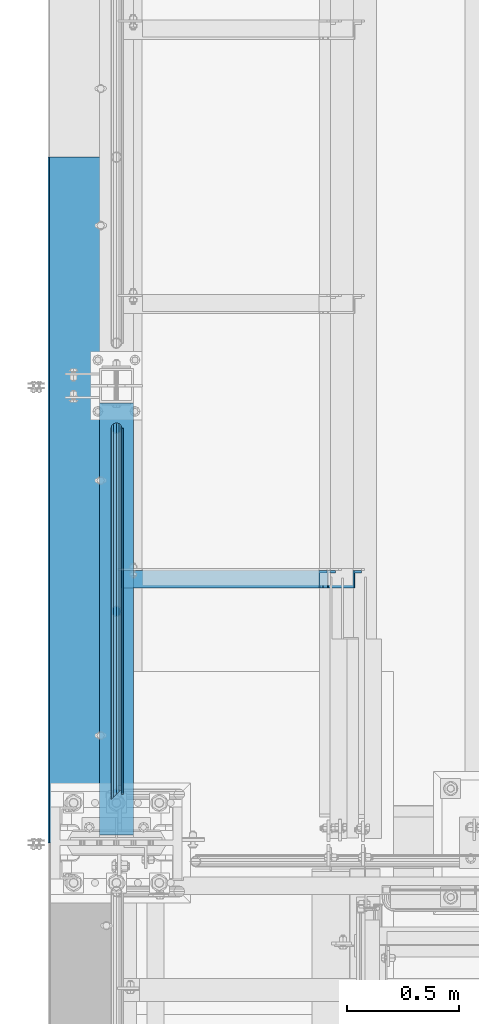
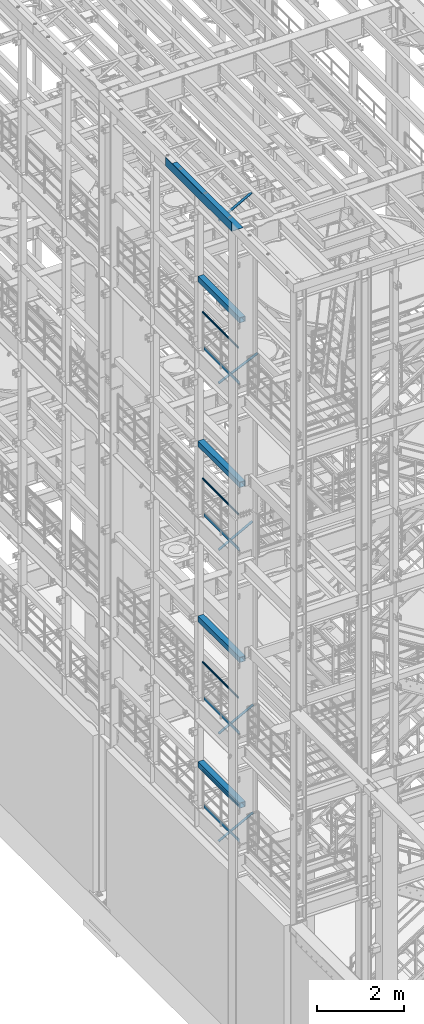
# One storey, part 970 of 1876: 13 beams, 5 members, 14 elements without a shape of their own.
"""IFC2X3 building model written with IfcOpenShell, lengths in millimetres."""

import ifcopenshell
import ifcopenshell.guid

model = None  # the IFC model being written
_history = None  # IfcOwnerHistory: only IFC2X3 demands one
_inside = {}  # id of a spatial element -> (the spatial element, [elements in it])
_under = {}  # id of a project, library or spatial element -> (it, [spatial elements below it])
_declared = {}  # id of a project -> (the project, [libraries it declares])
_typed = {}  # id of a type object -> (the type object, [elements of that type])
_made_of = {}  # id of a material, layer set ... -> (it, [elements and type objects made of it])


def new_model(schema):
    """Start an empty IFC model of exactly this schema.

    Asked for "IFC4X3", IfcOpenShell would pick the latest addendum, in which some entities
    have other attributes; the version numbers below select the first issue.
    IFC2X3 requires an IfcOwnerHistory on every rooted entity: one is made here for all.
    """
    global model, _history
    if schema == "IFC4X3":
        model = ifcopenshell.file(schema_version=(4, 3, 0, 0))
    else:
        model = ifcopenshell.file(schema=schema)
    _inside.clear()
    _under.clear()
    _declared.clear()
    _typed.clear()
    _made_of.clear()
    _history = None
    if model.schema == "IFC2X3":
        org = make("IfcOrganization", Name="unknown")
        user = make(
            "IfcPersonAndOrganization",
            ThePerson=make("IfcPerson", FamilyName="unknown"),
            TheOrganization=org,
        )
        app = make(
            "IfcApplication",
            ApplicationDeveloper=org,
            Version="unknown",
            ApplicationFullName="unknown",
            ApplicationIdentifier="unknown",
        )
        _history = make(
            "IfcOwnerHistory",
            OwningUser=user,
            OwningApplication=app,
            ChangeAction="ADDED",
            CreationDate=0,
        )
    return model


def make(cls, **values):
    """One entity of the class cls with the attributes given. An attribute that is None is left unset."""
    return model.create_entity(
        cls, **{name: value for name, value in values.items() if value is not None}
    )


def rooted(cls, **values):
    """An entity with a GlobalId (a new one), such as an element, a storey or a relation."""
    return make(cls, GlobalId=ifcopenshell.guid.new(), OwnerHistory=_history, **values)


def si_unit(unit_type, name, prefix=None):
    """IfcSIUnit, for example si_unit("LENGTHUNIT", "METRE", prefix="MILLI")."""
    return make("IfcSIUnit", UnitType=unit_type, Prefix=prefix, Name=name)


def assignment(units):
    """IfcUnitAssignment: the units of a project."""
    return None if units is None else make("IfcUnitAssignment", Units=units)


def point(xyz):
    """IfcCartesianPoint."""
    return None if xyz is None else make("IfcCartesianPoint", Coordinates=xyz)


def direction(xyz):
    """IfcDirection."""
    return None if xyz is None else make("IfcDirection", DirectionRatios=xyz)


def frame(location, z_axis=None, x_axis=None):
    """IfcAxis2Placement3D, a coordinate frame: its origin and axes. An axis left out is left unset."""
    return make(
        "IfcAxis2Placement3D",
        Location=point(location),
        Axis=direction(z_axis),
        RefDirection=direction(x_axis),
    )


def origin_with_axes():
    """The frame at (0, 0, 0) with the z axis (0, 0, 1) and the x axis (1, 0, 0) written out."""
    return frame((0.0, 0.0, 0.0), z_axis=(0.0, 0.0, 1.0), x_axis=(1.0, 0.0, 0.0))


def place(relative_to, where):
    """IfcLocalPlacement: puts the frame where relative to a parent placement (None: the world)."""
    return make(
        "IfcLocalPlacement", PlacementRelTo=relative_to, RelativePlacement=where
    )


def context(
    kind, dimensions, precision=None, world=None, true_north=None, identifier=None
):
    """IfcGeometricRepresentationContext, for example the 3D "Model" context."""
    return make(
        "IfcGeometricRepresentationContext",
        ContextIdentifier=identifier,
        ContextType=kind,
        CoordinateSpaceDimension=dimensions,
        Precision=precision,
        WorldCoordinateSystem=world,
        TrueNorth=true_north,
    )


def subcontext(parent, identifier, kind, view, scale=None):
    """IfcGeometricRepresentationSubContext, for example "Body" below "Model"."""
    return make(
        "IfcGeometricRepresentationSubContext",
        ContextIdentifier=identifier,
        ContextType=kind,
        ParentContext=parent,
        TargetScale=scale,
        TargetView=view,
    )


def project(units=None, contexts=None):
    """IfcProject with its units and contexts."""
    return rooted(
        "IfcProject",
        Name="project",
        RepresentationContexts=contexts,
        UnitsInContext=assignment(units),
    )


def spatial(cls, under=None, at=None, **own):
    """A site, building, storey or space (cls), placed at a placement, below another one or the project."""
    s = rooted(cls, ObjectPlacement=at, **own)
    if under is not None:
        _under.setdefault(under.id(), (under, []))[1].append(s)
    return s


def faces_of(points, faces, orient=None, outer=None):
    """IfcFace entities. A face is a list of loops; a loop is a list of indices into points, from 0.

    orient and outer hold one flag for each loop. By default every Orientation is true, the
    first loop of a face is its IfcFaceOuterBound and the others are IfcFaceBound.
    """
    made = []
    for i, loops in enumerate(faces):
        bounds = []
        for j, loop in enumerate(loops):
            is_outer = j == 0 if outer is None else outer[i][j]
            bounds.append(
                make(
                    "IfcFaceOuterBound" if is_outer else "IfcFaceBound",
                    Bound=make("IfcPolyLoop", Polygon=[points[k] for k in loop]),
                    Orientation=True if orient is None else orient[i][j],
                )
            )
        made.append(make("IfcFace", Bounds=bounds))
    return made


def faceted_brep(points, faces, orient=None, outer=None, voids=None):
    """IfcFacetedBrep: a solid bounded by flat faces; with voids (closed shells), ...WithVoids."""
    shared = [point(p) for p in points]
    hull = make("IfcClosedShell", CfsFaces=faces_of(shared, faces, orient, outer))
    if voids is None:
        return make("IfcFacetedBrep", Outer=hull)
    return make(
        "IfcFacetedBrepWithVoids",
        Outer=hull,
        Voids=[
            make(cls, CfsFaces=faces_of(shared, fs, o, b)) for cls, fs, o, b in voids
        ],
    )


def shape(context_of_items, identifier, shape_type, items):
    """IfcShapeRepresentation: the items that make up one representation, for example the "Body"."""
    return make(
        "IfcShapeRepresentation",
        ContextOfItems=context_of_items,
        RepresentationIdentifier=identifier,
        RepresentationType=shape_type,
        Items=items,
    )


def material(Name=None, Category=None):
    """IfcMaterial."""
    return make("IfcMaterial", Name=Name, Category=Category)


def made_of(thing, what):
    """Note that an element or type object is made of a material, layer set ...; save() writes the relation."""
    if what is not None:
        _made_of.setdefault(what.id(), (what, []))[1].append(thing)
    return thing


def type_object(cls, material=None, **own):
    """A type object (cls), such as IfcWallType, which elements share."""
    return made_of(rooted(cls, **own), material)


def element(
    cls,
    number,
    at=None,
    inside=None,
    cuts=None,
    type_object=None,
    material=None,
    context=None,
    identifier="Body",
    shape_type=None,
    held_by="IfcProductDefinitionShape",
    body=None,
    shapes=None,
    **own,
):
    """One element of the class cls, such as IfcWall. Its Tag is "e" and its number.

    at: its placement. inside: the storey or other place that contains it. cuts: it is an
    opening in that element (IfcRelVoidsElement). A single representation is given by context,
    identifier, shape_type and body (its items); several are given by shapes. held_by: the class
    of the entity that holds the representations. save() writes the other relations.
    """
    e = rooted(cls, Tag="e%d" % number, ObjectPlacement=at, **own)
    if body is not None:
        shapes = [shape(context, identifier, shape_type, body)]
    if shapes is not None:
        e.Representation = make(held_by, Representations=shapes)
    if inside is not None:
        _inside.setdefault(inside.id(), (inside, []))[1].append(e)
    if cuts is not None:
        rooted(
            "IfcRelVoidsElement", RelatingBuildingElement=cuts, RelatedOpeningElement=e
        )
    if type_object is not None:
        _typed.setdefault(type_object.id(), (type_object, []))[1].append(e)
    return made_of(e, material)


def aggregate(whole, parts):
    """IfcRelAggregates: a whole, such as a stair, and the parts it consists of."""
    return rooted("IfcRelAggregates", RelatingObject=whole, RelatedObjects=parts)


def save(model, path):
    """Write the relations noted so far, then the file.

    IfcRelAggregates (storeys below a building ...), IfcRelContainedInSpatialStructure (elements
    in a storey), IfcRelDefinesByType, IfcRelAssociatesMaterial and IfcRelDeclares: one each for
    every whole, place, type object, material and project.
    """
    for whole, parts in _under.values():
        aggregate(whole, parts)
    for where, things in _inside.values():
        rooted(
            "IfcRelContainedInSpatialStructure",
            RelatedElements=things,
            RelatingStructure=where,
        )
    for kind, things in _typed.values():
        rooted("IfcRelDefinesByType", RelatedObjects=things, RelatingType=kind)
    for what, things in _made_of.values():
        rooted("IfcRelAssociatesMaterial", RelatedObjects=things, RelatingMaterial=what)
    for by, libraries in _declared.values():
        rooted("IfcRelDeclares", RelatingContext=by, RelatedDefinitions=libraries)
    model.write(path)


model = new_model("IFC2X3")

# Units and contexts
model_context = context("Model", 3, precision=1e-05, world=origin_with_axes())
body_context = subcontext(model_context, "Body", "Model", "MODEL_VIEW")
ifc_project = project(units=[si_unit("LENGTHUNIT", "METRE", prefix="MILLI"), si_unit("AREAUNIT", "SQUARE_METRE"), si_unit("VOLUMEUNIT", "CUBIC_METRE"), si_unit("MASSUNIT", "GRAM", prefix="KILO"), si_unit("TIMEUNIT", "SECOND"), si_unit("PLANEANGLEUNIT", "RADIAN"), si_unit("SOLIDANGLEUNIT", "STERADIAN"), si_unit("THERMODYNAMICTEMPERATUREUNIT", "DEGREE_CELSIUS"), si_unit("LUMINOUSINTENSITYUNIT", "LUMEN")], contexts=[model_context])

# Site, building, storey
site_placement = place(None, origin_with_axes())
site = spatial("IfcSite", under=ifc_project, at=site_placement, CompositionType="ELEMENT")
building_placement = place(site_placement, origin_with_axes())
building = spatial("IfcBuilding", under=site, at=building_placement, Name="Undefined", CompositionType="ELEMENT")
storey_placement = place(building_placement, origin_with_axes())
storey = spatial("IfcBuildingStorey", under=building, at=storey_placement, Name="Undefined", CompositionType="ELEMENT", Elevation=0.0)

# Assembly, beam
assembly_1_placement = place(storey_placement, origin_with_axes())
assembly_1 = element("IfcElementAssembly", 1, at=assembly_1_placement, inside=storey, Name="RAIL", AssemblyPlace="NOTDEFINED", PredefinedType="RIGID_FRAME")
ifc_material_1 = material()
beam_type_1 = type_object("IfcBeamType", Name="PIPE1-1/2SCH40", PredefinedType="NOTDEFINED")
beam_1_placement = place(assembly_1_placement, frame((-4.42285052611689e-13, -4380.23, 19059.525), z_axis=(0.0, 0.0, -1.0), x_axis=(0.0, 1.0, 0.0)))
beam_1 = element("IfcBeam", 2, at=beam_1_placement, type_object=beam_type_1, material=ifc_material_1, Name="RAIL", ObjectType="PIPE1-1/2SCH40", context=body_context, shape_type="Brep", body=[
    faceted_brep([(3.68299999999272, -20.447, 0.0), (6.42237856881275, -17.7076214311804, 10.2235000000001), (1640.7003, -17.7076214311801, 10.2235000000001), (1650.9238, -20.4470000000001, 0.0), (13.9064999999928, -10.2235, 17.7076214311819), (1633.21617856882, -10.2235000000001, 17.7076214311819), (24.1300000000064, 0.0, 20.4470000000001), (1630.4768, 0.0, 20.4470000000001), (34.3534999999929, 10.2235, 17.7076214311819), (1633.21617856882, 10.2235000000001, 17.7076214311819), (41.8376214311729, 17.7076214311804, 10.2235000000001), (1640.7003, 17.7076214311801, 10.2235000000001), (44.5769999999929, 20.447, 0.0), (1650.9238, 20.4470000000001, 0.0), (41.8376214311729, 17.7076214311804, -10.2235000000001), (1661.1473, 17.7076214311801, -10.2235000000001), (34.3534999999929, 10.2235, -17.7076214311819), (1668.63142143118, 10.2235000000001, -17.7076214311819), (24.1300000000063, 0.0, -20.4470000000001), (1671.3708, 0.0, -20.4470000000001), (13.9064999999928, -10.2235, -17.7076214311819), (1668.63142143118, -10.2235000000001, -17.7076214311819), (6.42237856881275, -17.7076214311804, -10.2235000000001), (1661.1473, -17.7076214311801, -10.2235000000001), (0.0, -24.1299999999992, 0.0), (3.23280700667419, -20.8971929933185, -12.0649999999987), (1662.9888, -20.8971929933186, -12.0649999999987), (1650.9238, -24.1300000000001, 0.0), (12.0649999999854, -12.0650000000005, -20.8971929933177), (1671.82099299332, -12.0649999999996, -20.8971929933177), (24.1300000000063, 0.0, -24.130000000001), (1675.0538, 0.0, -24.130000000001), (36.1949999999924, 12.065, -20.8971929933177), (1671.82099299332, 12.0649999999996, -20.8971929933177), (45.0271929933115, 20.8971929933185, -12.0649999999987), (1662.9888, 20.8971929933186, -12.0649999999987), (48.2599999999929, 24.13, 0.0), (1650.9238, 24.1300000000001, 0.0), (45.0271929933115, 20.8971929933185, 12.0649999999987), (1638.8588, 20.8971929933186, 12.0649999999987), (36.1949999999924, 12.065, 20.8971929933177), (1630.02660700668, 12.0649999999996, 20.8971929933177), (24.1300000000064, 0.0, 24.130000000001), (1626.7938, 0.0, 24.130000000001), (12.0649999999854, -12.0650000000005, 20.8971929933177), (1630.02660700668, -12.0649999999996, 20.8971929933177), (3.23280700667419, -20.8971929933185, 12.0649999999987), (1638.8588, -20.8971929933186, 12.0649999999987)], [[[0, 1, 2, 3]], [[1, 4, 5, 2]], [[4, 6, 7, 5]], [[6, 8, 9, 7]], [[8, 10, 11, 9]], [[10, 12, 13, 11]], [[12, 14, 15, 13]], [[14, 16, 17, 15]], [[16, 18, 19, 17]], [[18, 20, 21, 19]], [[20, 22, 23, 21]], [[22, 0, 3, 23]], [[24, 25, 26, 27]], [[25, 28, 29, 26]], [[28, 30, 31, 29]], [[30, 32, 33, 31]], [[32, 34, 35, 33]], [[34, 36, 37, 35]], [[36, 38, 39, 37]], [[38, 40, 41, 39]], [[40, 42, 43, 41]], [[42, 44, 45, 43]], [[44, 46, 47, 45]], [[46, 24, 27, 47]], [[29, 31, 33, 35, 37, 39, 41, 43, 45, 47, 27, 26], [5, 7, 9, 11, 13, 15, 17, 19, 21, 23, 3, 2]], [[46, 44, 42, 40, 38, 36, 34, 32, 30, 28, 25, 24], [22, 20, 18, 16, 14, 12, 10, 8, 6, 4, 1, 0]]]),
])

assembly_2_placement = place(storey_placement, origin_with_axes())
assembly_2 = element("IfcElementAssembly", 3, at=assembly_2_placement, inside=storey, Name="RAIL", AssemblyPlace="NOTDEFINED", PredefinedType="RIGID_FRAME")
beam_2_placement = place(assembly_2_placement, frame((-4.42285052611689e-13, -4380.23, 14385.925), z_axis=(0.0, 0.0, -1.0), x_axis=(0.0, 1.0, 0.0)))
beam_2 = element("IfcBeam", 4, at=beam_2_placement, type_object=beam_type_1, material=ifc_material_1, Name="RAIL", ObjectType="PIPE1-1/2SCH40", context=body_context, shape_type="Brep", body=[
    faceted_brep([(3.68299999999272, -20.447, 0.0), (6.42237856881275, -17.7076214311804, 10.2235000000001), (1640.7003, -17.7076214311801, 10.2235000000001), (1650.9238, -20.4470000000001, 0.0), (13.9064999999928, -10.2235, 17.7076214311819), (1633.21617856882, -10.2235000000001, 17.7076214311819), (24.1300000000064, 0.0, 20.4470000000001), (1630.4768, 0.0, 20.4470000000001), (34.3534999999929, 10.2235, 17.7076214311819), (1633.21617856882, 10.2235000000001, 17.7076214311819), (41.8376214311729, 17.7076214311804, 10.2235000000001), (1640.7003, 17.7076214311801, 10.2235000000001), (44.5769999999929, 20.447, 0.0), (1650.9238, 20.4470000000001, 0.0), (41.8376214311729, 17.7076214311804, -10.2235000000001), (1661.1473, 17.7076214311801, -10.2235000000001), (34.3534999999929, 10.2235, -17.7076214311819), (1668.63142143118, 10.2235000000001, -17.7076214311819), (24.1300000000063, 0.0, -20.4470000000001), (1671.3708, 0.0, -20.4470000000001), (13.9064999999928, -10.2235, -17.7076214311819), (1668.63142143118, -10.2235000000001, -17.7076214311819), (6.42237856881275, -17.7076214311804, -10.2235000000001), (1661.1473, -17.7076214311801, -10.2235000000001), (0.0, -24.1299999999992, 0.0), (3.23280700667419, -20.8971929933185, -12.0649999999987), (1662.9888, -20.8971929933186, -12.0649999999987), (1650.9238, -24.1300000000001, 0.0), (12.0649999999854, -12.0650000000005, -20.8971929933177), (1671.82099299332, -12.0649999999996, -20.8971929933177), (24.1300000000063, 0.0, -24.130000000001), (1675.0538, 0.0, -24.130000000001), (36.1949999999924, 12.065, -20.8971929933177), (1671.82099299332, 12.0649999999996, -20.8971929933177), (45.0271929933115, 20.8971929933185, -12.0649999999987), (1662.9888, 20.8971929933186, -12.0649999999987), (48.2599999999929, 24.13, 0.0), (1650.9238, 24.1300000000001, 0.0), (45.0271929933115, 20.8971929933185, 12.0649999999987), (1638.8588, 20.8971929933186, 12.0649999999987), (36.1949999999924, 12.065, 20.8971929933177), (1630.02660700668, 12.0649999999996, 20.8971929933177), (24.1300000000064, 0.0, 24.130000000001), (1626.7938, 0.0, 24.130000000001), (12.0649999999854, -12.0650000000005, 20.8971929933177), (1630.02660700668, -12.0649999999996, 20.8971929933177), (3.23280700667419, -20.8971929933185, 12.0649999999987), (1638.8588, -20.8971929933186, 12.0649999999987)], [[[0, 1, 2, 3]], [[1, 4, 5, 2]], [[4, 6, 7, 5]], [[6, 8, 9, 7]], [[8, 10, 11, 9]], [[10, 12, 13, 11]], [[12, 14, 15, 13]], [[14, 16, 17, 15]], [[16, 18, 19, 17]], [[18, 20, 21, 19]], [[20, 22, 23, 21]], [[22, 0, 3, 23]], [[24, 25, 26, 27]], [[25, 28, 29, 26]], [[28, 30, 31, 29]], [[30, 32, 33, 31]], [[32, 34, 35, 33]], [[34, 36, 37, 35]], [[36, 38, 39, 37]], [[38, 40, 41, 39]], [[40, 42, 43, 41]], [[42, 44, 45, 43]], [[44, 46, 47, 45]], [[46, 24, 27, 47]], [[29, 31, 33, 35, 37, 39, 41, 43, 45, 47, 27, 26], [5, 7, 9, 11, 13, 15, 17, 19, 21, 23, 3, 2]], [[46, 44, 42, 40, 38, 36, 34, 32, 30, 28, 25, 24], [22, 20, 18, 16, 14, 12, 10, 8, 6, 4, 1, 0]]]),
])

assembly_3_placement = place(storey_placement, origin_with_axes())
assembly_3 = element("IfcElementAssembly", 5, at=assembly_3_placement, inside=storey, Name="RAIL", AssemblyPlace="NOTDEFINED", PredefinedType="RIGID_FRAME")
beam_3_placement = place(assembly_3_placement, frame((-4.42285052611689e-13, -4380.23, 9229.725), z_axis=(0.0, 0.0, -1.0), x_axis=(0.0, 1.0, 0.0)))
beam_3 = element("IfcBeam", 6, at=beam_3_placement, type_object=beam_type_1, material=ifc_material_1, Name="RAIL", ObjectType="PIPE1-1/2SCH40", context=body_context, shape_type="Brep", body=[
    faceted_brep([(3.68299999999272, -20.447, 0.0), (6.42237856881275, -17.7076214311804, 10.2235000000001), (1640.7003, -17.7076214311801, 10.2235000000001), (1650.9238, -20.4470000000001, 0.0), (13.9064999999928, -10.2235, 17.7076214311819), (1633.21617856882, -10.2235000000001, 17.7076214311819), (24.1300000000064, 0.0, 20.4470000000001), (1630.4768, 0.0, 20.4470000000001), (34.3534999999929, 10.2235, 17.7076214311819), (1633.21617856882, 10.2235000000001, 17.7076214311819), (41.8376214311729, 17.7076214311804, 10.2235000000001), (1640.7003, 17.7076214311801, 10.2235000000001), (44.5769999999929, 20.447, 0.0), (1650.9238, 20.4470000000001, 0.0), (41.8376214311729, 17.7076214311804, -10.2235000000001), (1661.1473, 17.7076214311801, -10.2235000000001), (34.3534999999929, 10.2235, -17.7076214311819), (1668.63142143118, 10.2235000000001, -17.7076214311819), (24.1300000000063, 0.0, -20.4470000000001), (1671.3708, 0.0, -20.4470000000001), (13.9064999999928, -10.2235, -17.7076214311819), (1668.63142143118, -10.2235000000001, -17.7076214311819), (6.42237856881275, -17.7076214311804, -10.2235000000001), (1661.1473, -17.7076214311801, -10.2235000000001), (0.0, -24.1299999999992, 0.0), (3.23280700667419, -20.8971929933185, -12.0649999999987), (1662.9888, -20.8971929933186, -12.0649999999987), (1650.9238, -24.1300000000001, 0.0), (12.0649999999854, -12.0650000000005, -20.8971929933177), (1671.82099299332, -12.0649999999996, -20.8971929933177), (24.1300000000063, 0.0, -24.130000000001), (1675.0538, 0.0, -24.130000000001), (36.1949999999924, 12.065, -20.8971929933177), (1671.82099299332, 12.0649999999996, -20.8971929933177), (45.0271929933115, 20.8971929933185, -12.0649999999987), (1662.9888, 20.8971929933186, -12.0649999999987), (48.2599999999929, 24.13, 0.0), (1650.9238, 24.1300000000001, 0.0), (45.0271929933115, 20.8971929933185, 12.0649999999987), (1638.8588, 20.8971929933186, 12.0649999999987), (36.1949999999924, 12.065, 20.8971929933177), (1630.02660700668, 12.0649999999996, 20.8971929933177), (24.1300000000064, 0.0, 24.130000000001), (1626.7938, 0.0, 24.130000000001), (12.0649999999854, -12.0650000000005, 20.8971929933177), (1630.02660700668, -12.0649999999996, 20.8971929933177), (3.23280700667419, -20.8971929933185, 12.0649999999987), (1638.8588, -20.8971929933186, 12.0649999999987)], [[[0, 1, 2, 3]], [[1, 4, 5, 2]], [[4, 6, 7, 5]], [[6, 8, 9, 7]], [[8, 10, 11, 9]], [[10, 12, 13, 11]], [[12, 14, 15, 13]], [[14, 16, 17, 15]], [[16, 18, 19, 17]], [[18, 20, 21, 19]], [[20, 22, 23, 21]], [[22, 0, 3, 23]], [[24, 25, 26, 27]], [[25, 28, 29, 26]], [[28, 30, 31, 29]], [[30, 32, 33, 31]], [[32, 34, 35, 33]], [[34, 36, 37, 35]], [[36, 38, 39, 37]], [[38, 40, 41, 39]], [[40, 42, 43, 41]], [[42, 44, 45, 43]], [[44, 46, 47, 45]], [[46, 24, 27, 47]], [[29, 31, 33, 35, 37, 39, 41, 43, 45, 47, 27, 26], [5, 7, 9, 11, 13, 15, 17, 19, 21, 23, 3, 2]], [[46, 44, 42, 40, 38, 36, 34, 32, 30, 28, 25, 24], [22, 20, 18, 16, 14, 12, 10, 8, 6, 4, 1, 0]]]),
])

assembly_4_placement = place(storey_placement, origin_with_axes())
assembly_4 = element("IfcElementAssembly", 7, at=assembly_4_placement, inside=storey, Name="RAIL", AssemblyPlace="NOTDEFINED", PredefinedType="RIGID_FRAME")
beam_4_placement = place(assembly_4_placement, frame((-4.42285052611689e-13, -4380.23, 6207.125), z_axis=(0.0, 0.0, -1.0), x_axis=(0.0, 1.0, 0.0)))
beam_4 = element("IfcBeam", 8, at=beam_4_placement, type_object=beam_type_1, material=ifc_material_1, Name="RAIL", ObjectType="PIPE1-1/2SCH40", context=body_context, shape_type="Brep", body=[
    faceted_brep([(3.68299999999272, -20.447, 0.0), (6.42237856881275, -17.7076214311804, 10.2235000000001), (1640.7003, -17.7076214311801, 10.2235000000001), (1650.9238, -20.4470000000001, 0.0), (13.9064999999928, -10.2235, 17.7076214311819), (1633.21617856882, -10.2235000000001, 17.7076214311819), (24.1300000000064, 0.0, 20.4470000000001), (1630.4768, 0.0, 20.4470000000001), (34.3534999999929, 10.2235, 17.7076214311819), (1633.21617856882, 10.2235000000001, 17.7076214311819), (41.8376214311729, 17.7076214311804, 10.2235000000001), (1640.7003, 17.7076214311801, 10.2235000000001), (44.5769999999929, 20.447, 0.0), (1650.9238, 20.4470000000001, 0.0), (41.8376214311729, 17.7076214311804, -10.2235000000001), (1661.1473, 17.7076214311801, -10.2235000000001), (34.3534999999929, 10.2235, -17.7076214311819), (1668.63142143118, 10.2235000000001, -17.7076214311819), (24.1300000000063, 0.0, -20.4470000000001), (1671.3708, 0.0, -20.4470000000001), (13.9064999999928, -10.2235, -17.7076214311819), (1668.63142143118, -10.2235000000001, -17.7076214311819), (6.42237856881275, -17.7076214311804, -10.2235000000001), (1661.1473, -17.7076214311801, -10.2235000000001), (0.0, -24.1299999999992, 0.0), (3.23280700667419, -20.8971929933185, -12.0649999999987), (1662.9888, -20.8971929933186, -12.0649999999987), (1650.9238, -24.1300000000001, 0.0), (12.0649999999854, -12.0650000000005, -20.8971929933177), (1671.82099299332, -12.0649999999996, -20.8971929933177), (24.1300000000063, 0.0, -24.130000000001), (1675.0538, 0.0, -24.130000000001), (36.1949999999924, 12.065, -20.8971929933177), (1671.82099299332, 12.0649999999996, -20.8971929933177), (45.0271929933115, 20.8971929933185, -12.0649999999987), (1662.9888, 20.8971929933186, -12.0649999999987), (48.2599999999929, 24.13, 0.0), (1650.9238, 24.1300000000001, 0.0), (45.0271929933115, 20.8971929933185, 12.0649999999987), (1638.8588, 20.8971929933186, 12.0649999999987), (36.1949999999924, 12.065, 20.8971929933177), (1630.02660700668, 12.0649999999996, 20.8971929933177), (24.1300000000064, 0.0, 24.130000000001), (1626.7938, 0.0, 24.130000000001), (12.0649999999854, -12.0650000000005, 20.8971929933177), (1630.02660700668, -12.0649999999996, 20.8971929933177), (3.23280700667419, -20.8971929933185, 12.0649999999987), (1638.8588, -20.8971929933186, 12.0649999999987)], [[[0, 1, 2, 3]], [[1, 4, 5, 2]], [[4, 6, 7, 5]], [[6, 8, 9, 7]], [[8, 10, 11, 9]], [[10, 12, 13, 11]], [[12, 14, 15, 13]], [[14, 16, 17, 15]], [[16, 18, 19, 17]], [[18, 20, 21, 19]], [[20, 22, 23, 21]], [[22, 0, 3, 23]], [[24, 25, 26, 27]], [[25, 28, 29, 26]], [[28, 30, 31, 29]], [[30, 32, 33, 31]], [[32, 34, 35, 33]], [[34, 36, 37, 35]], [[36, 38, 39, 37]], [[38, 40, 41, 39]], [[40, 42, 43, 41]], [[42, 44, 45, 43]], [[44, 46, 47, 45]], [[46, 24, 27, 47]], [[29, 31, 33, 35, 37, 39, 41, 43, 45, 47, 27, 26], [5, 7, 9, 11, 13, 15, 17, 19, 21, 23, 3, 2]], [[46, 44, 42, 40, 38, 36, 34, 32, 30, 28, 25, 24], [22, 20, 18, 16, 14, 12, 10, 8, 6, 4, 1, 0]]]),
])

assembly_5_placement = place(storey_placement, origin_with_axes())
assembly_5 = element("IfcElementAssembly", 9, at=assembly_5_placement, inside=storey, Name="BEAM", AssemblyPlace="NOTDEFINED", PredefinedType="RIGID_FRAME")
ifc_material_2 = material()
beam_type_2 = type_object("IfcBeamType", Name="HSS6X6X3/8", PredefinedType="NOTDEFINED")
beam_5_placement = place(assembly_5_placement, frame((0.0, -4560.09375, 19958.05), z_axis=(-1.0, 0.0, 0.0), x_axis=(0.0, 1.0, 0.0)))
beam_5 = element("IfcBeam", 10, at=beam_5_placement, type_object=beam_type_2, material=ifc_material_2, Name="BEAM", ObjectType="HSS6X6X3/8", context=body_context, shape_type="Brep", body=[
    faceted_brep([(22.2249999999995, 66.6749999999993, -66.675), (22.2249999999995, -66.6749999999993, -66.675), (1943.89375, -66.6749999999993, -66.675), (1943.89375, 66.6749999999993, -66.675), (22.2249999999995, -66.6749999999993, 66.675), (1943.89375, -66.6749999999993, 66.675), (22.2249999999995, 66.6749999999993, 66.675), (1943.89375, 66.6749999999993, 66.675), (22.2249999999995, 76.2000000000007, -76.2), (22.2249999999995, 76.2000000000007, 76.2), (1943.89375, 76.2000000000007, 76.2), (1943.89375, 76.2000000000007, -76.2), (22.2249999999995, -76.2000000000007, 76.2), (1943.89375, -76.2000000000007, 76.2), (22.2249999999995, -76.2000000000007, -76.2), (1943.89375, -76.2000000000007, -76.2)], [[[0, 1, 2, 3]], [[1, 4, 5, 2]], [[4, 6, 7, 5]], [[6, 0, 3, 7]], [[8, 9, 10, 11]], [[9, 12, 13, 10]], [[12, 14, 15, 13]], [[14, 8, 11, 15]], [[13, 15, 11, 10], [5, 7, 3, 2]], [[14, 12, 9, 8], [6, 4, 1, 0]]]),
])
aggregate(assembly_5, [beam_5])

assembly_6_placement = place(storey_placement, origin_with_axes())
assembly_6 = element("IfcElementAssembly", 11, at=assembly_6_placement, inside=storey, Name="BEAM", AssemblyPlace="NOTDEFINED", PredefinedType="RIGID_FRAME")
beam_6_placement = place(assembly_6_placement, frame((0.0, -4560.09375, 15335.25), z_axis=(-1.0, 0.0, 0.0), x_axis=(0.0, 1.0, 0.0)))
beam_6 = element("IfcBeam", 12, at=beam_6_placement, type_object=beam_type_2, material=ifc_material_2, Name="BEAM", ObjectType="HSS6X6X3/8", context=body_context, shape_type="Brep", body=[
    faceted_brep([(22.2249999999995, 66.6749999999993, -66.675), (22.2249999999995, -66.6749999999993, -66.675), (1943.89375, -66.6749999999993, -66.675), (1943.89375, 66.6749999999993, -66.675), (22.2249999999995, -66.6749999999993, 66.675), (1943.89375, -66.6749999999993, 66.675), (22.2249999999995, 66.6749999999993, 66.675), (1943.89375, 66.6749999999993, 66.675), (22.2249999999995, 76.2000000000007, -76.2), (22.2249999999995, 76.2000000000007, 76.2), (1943.89375, 76.2000000000007, 76.2), (1943.89375, 76.2000000000007, -76.2), (22.2249999999995, -76.2000000000007, 76.2), (1943.89375, -76.2000000000007, 76.2), (22.2249999999995, -76.2000000000007, -76.2), (1943.89375, -76.2000000000007, -76.2)], [[[0, 1, 2, 3]], [[1, 4, 5, 2]], [[4, 6, 7, 5]], [[6, 0, 3, 7]], [[8, 9, 10, 11]], [[9, 12, 13, 10]], [[12, 14, 15, 13]], [[14, 8, 11, 15]], [[13, 15, 11, 10], [5, 7, 3, 2]], [[14, 12, 9, 8], [6, 4, 1, 0]]]),
])
aggregate(assembly_6, [beam_6])

assembly_7_placement = place(storey_placement, origin_with_axes())
assembly_7 = element("IfcElementAssembly", 13, at=assembly_7_placement, inside=storey, Name="BEAM", AssemblyPlace="NOTDEFINED", PredefinedType="RIGID_FRAME")
beam_7_placement = place(assembly_7_placement, frame((0.0, -4560.09375, 10420.35), z_axis=(-1.0, 0.0, 0.0), x_axis=(0.0, 1.0, 0.0)))
beam_7 = element("IfcBeam", 14, at=beam_7_placement, type_object=beam_type_2, material=ifc_material_2, Name="BEAM", ObjectType="HSS6X6X3/8", context=body_context, shape_type="Brep", body=[
    faceted_brep([(22.2249999999995, 66.6749999999993, -66.675), (22.2249999999995, -66.6749999999993, -66.675), (1943.89375, -66.6749999999993, -66.675), (1943.89375, 66.6749999999993, -66.675), (22.2249999999995, -66.6749999999993, 66.675), (1943.89375, -66.6749999999993, 66.675), (22.2249999999995, 66.6749999999993, 66.675), (1943.89375, 66.6749999999993, 66.675), (22.2249999999995, 76.2000000000007, -76.2), (22.2249999999995, 76.2000000000007, 76.2), (1943.89375, 76.2000000000007, 76.2), (1943.89375, 76.2000000000007, -76.2), (22.2249999999995, -76.2000000000007, 76.2), (1943.89375, -76.2000000000007, 76.2), (22.2249999999995, -76.2000000000007, -76.2), (1943.89375, -76.2000000000007, -76.2)], [[[0, 1, 2, 3]], [[1, 4, 5, 2]], [[4, 6, 7, 5]], [[6, 0, 3, 7]], [[8, 9, 10, 11]], [[9, 12, 13, 10]], [[12, 14, 15, 13]], [[14, 8, 11, 15]], [[13, 15, 11, 10], [5, 7, 3, 2]], [[14, 12, 9, 8], [6, 4, 1, 0]]]),
])
aggregate(assembly_7, [beam_7])

assembly_8_placement = place(storey_placement, origin_with_axes())
assembly_8 = element("IfcElementAssembly", 15, at=assembly_8_placement, inside=storey, Name="BEAM", AssemblyPlace="NOTDEFINED", PredefinedType="RIGID_FRAME")
beam_8_placement = place(assembly_8_placement, frame((0.0, -4560.09375, 6330.95), z_axis=(-1.0, 0.0, 0.0), x_axis=(0.0, 1.0, 0.0)))
beam_8 = element("IfcBeam", 16, at=beam_8_placement, type_object=beam_type_2, material=ifc_material_2, Name="BEAM", ObjectType="HSS6X6X3/8", context=body_context, shape_type="Brep", body=[
    faceted_brep([(22.2249999999995, 66.6749999999993, -66.675), (22.2249999999995, -66.6749999999993, -66.675), (1943.89375, -66.6749999999993, -66.675), (1943.89375, 66.6749999999993, -66.675), (22.2249999999995, -66.6749999999993, 66.675), (1943.89375, -66.6749999999993, 66.675), (22.2249999999995, 66.6749999999993, 66.675), (1943.89375, 66.6749999999993, 66.675), (22.2249999999995, 76.2000000000007, -76.2), (22.2249999999995, 76.2000000000007, 76.2), (1943.89375, 76.2000000000007, 76.2), (1943.89375, 76.2000000000007, -76.2), (22.2249999999995, -76.2000000000007, 76.2), (1943.89375, -76.2000000000007, 76.2), (22.2249999999995, -76.2000000000007, -76.2), (1943.89375, -76.2000000000007, -76.2)], [[[0, 1, 2, 3]], [[1, 4, 5, 2]], [[4, 6, 7, 5]], [[6, 0, 3, 7]], [[8, 9, 10, 11]], [[9, 12, 13, 10]], [[12, 14, 15, 13]], [[14, 8, 11, 15]], [[13, 15, 11, 10], [5, 7, 3, 2]], [[14, 12, 9, 8], [6, 4, 1, 0]]]),
])
aggregate(assembly_8, [beam_8])

# Beam
ifc_material_3 = material(Name="STEEL/A36")
beam_type_3 = type_object("IfcBeamType", PredefinedType="NOTDEFINED")
beam_9_placement = place(assembly_1_placement, frame((27.3049999999948, -4356.10000000001, 18049.875), z_axis=(0.0, 0.0, 1.0), x_axis=(0.0, 1.0, 0.0)))
beam_9 = element("IfcBeam", 17, at=beam_9_placement, type_object=beam_type_3, material=ifc_material_3, Name="PLATE", context=body_context, shape_type="Brep", body=[
    faceted_brep([(0.0, 3.17500000000018, -50.8000000000002), (0.0, 3.17500000000018, 50.8000000000002), (1626.7938, 3.175, 50.7999999999993), (1626.7938, 3.175, -50.7999999999993), (0.0, -3.17500000000018, 50.8000000000002), (1626.7938, -3.175, 50.7999999999993), (0.0, -3.17500000000018, -50.8000000000002), (1626.7938, -3.175, -50.7999999999993)], [[[0, 1, 2, 3]], [[1, 4, 5, 2]], [[4, 6, 7, 5]], [[6, 0, 3, 7]], [[5, 7, 3, 2]], [[6, 4, 1, 0]]]),
])

aggregate(assembly_1, [beam_9, beam_1])

beam_10_placement = place(assembly_2_placement, frame((27.3049999999948, -4356.10000000001, 13376.275), z_axis=(0.0, 0.0, 1.0), x_axis=(0.0, 1.0, 0.0)))
beam_10 = element("IfcBeam", 18, at=beam_10_placement, type_object=beam_type_3, material=ifc_material_3, Name="PLATE", context=body_context, shape_type="Brep", body=[
    faceted_brep([(0.0, 3.17500000000018, -50.8000000000002), (0.0, 3.17500000000018, 50.8000000000002), (1626.7938, 3.175, 50.7999999999993), (1626.7938, 3.175, -50.7999999999993), (0.0, -3.17500000000018, 50.8000000000002), (1626.7938, -3.175, 50.7999999999993), (0.0, -3.17500000000018, -50.8000000000002), (1626.7938, -3.175, -50.7999999999993)], [[[0, 1, 2, 3]], [[1, 4, 5, 2]], [[4, 6, 7, 5]], [[6, 0, 3, 7]], [[5, 7, 3, 2]], [[6, 4, 1, 0]]]),
])

aggregate(assembly_2, [beam_10, beam_2])

beam_11_placement = place(assembly_3_placement, frame((27.3049999999948, -4356.1, 8220.075), z_axis=(0.0, 0.0, 1.0), x_axis=(0.0, 1.0, 0.0)))
beam_11 = element("IfcBeam", 19, at=beam_11_placement, type_object=beam_type_3, material=ifc_material_3, Name="PLATE", context=body_context, shape_type="Brep", body=[
    faceted_brep([(0.0, 3.17500000000018, -50.8000000000002), (0.0, 3.17500000000018, 50.8000000000002), (1626.7938, 3.175, 50.7999999999993), (1626.7938, 3.175, -50.7999999999993), (0.0, -3.17500000000018, 50.8000000000002), (1626.7938, -3.175, 50.7999999999993), (0.0, -3.17500000000018, -50.8000000000002), (1626.7938, -3.175, -50.7999999999993)], [[[0, 1, 2, 3]], [[1, 4, 5, 2]], [[4, 6, 7, 5]], [[6, 0, 3, 7]], [[5, 7, 3, 2]], [[6, 4, 1, 0]]]),
])

aggregate(assembly_3, [beam_11, beam_3])

beam_12_placement = place(assembly_4_placement, frame((27.3049999999948, -4356.10000000001, 5197.475), z_axis=(0.0, 0.0, 1.0), x_axis=(0.0, 1.0, 0.0)))
beam_12 = element("IfcBeam", 20, at=beam_12_placement, type_object=beam_type_3, material=ifc_material_3, Name="PLATE", context=body_context, shape_type="Brep", body=[
    faceted_brep([(0.0, 3.17500000000018, -50.8000000000002), (0.0, 3.17500000000018, 50.8000000000002), (1626.7938, 3.175, 50.7999999999993), (1626.7938, 3.175, -50.7999999999993), (0.0, -3.17500000000018, 50.8000000000002), (1626.7938, -3.175, 50.7999999999993), (0.0, -3.17500000000018, -50.8000000000002), (1626.7938, -3.175, -50.7999999999993)], [[[0, 1, 2, 3]], [[1, 4, 5, 2]], [[4, 6, 7, 5]], [[6, 0, 3, 7]], [[5, 7, 3, 2]], [[6, 4, 1, 0]]]),
])

aggregate(assembly_4, [beam_12, beam_4])

# Assembly, member
assembly_9_placement = place(storey_placement, origin_with_axes())
assembly_9 = element("IfcElementAssembly", 21, at=assembly_9_placement, inside=storey, AssemblyPlace="NOTDEFINED", PredefinedType="RIGID_FRAME")
member_type = type_object("IfcMemberType", Name="L3X3X3/8", PredefinedType="NOTDEFINED")
member_1_placement = place(assembly_9_placement, frame((15.9156353109856, -3400.425, 17440.5834930797), z_axis=(0.0, -1.0, 0.0), x_axis=(0.908569735485921, 0.0, 0.417733211223436)))
member_1 = element("IfcMember", 22, at=member_1_placement, type_object=member_type, material=ifc_material_3, ObjectType="L3X3X3/8", context=body_context, shape_type="Brep", body=[
    faceted_brep([(21.8406460853457, 38.0999999999894, -38.0999999999999), (21.8406460853457, 38.0999999999894, 38.0999999999999), (1162.88335939537, 38.0999999996566, 38.0999999999999), (1162.88335939537, 38.0999999996566, -38.0999999999999), (21.8406460853494, 28.5749999999916, 38.0999999999999), (1162.88335939538, 28.5749999996551, 38.0999999999999), (21.8406460853494, 28.5749999999916, -28.5749999999998), (1162.88335939538, 28.5749999996551, -28.5749999999998), (21.8406460853721, -38.1000000000022, -28.5749999999998), (1162.8833593954, -38.1000000003332, -28.5749999999998), (21.8406460853721, -38.1000000000022, -38.0999999999999), (1162.8833593954, -38.1000000003332, -38.0999999999999)], [[[0, 1, 2, 3]], [[1, 4, 5, 2]], [[4, 6, 7, 5]], [[6, 8, 9, 7]], [[8, 10, 11, 9]], [[10, 0, 3, 11]], [[5, 7, 9, 11, 3, 2]], [[10, 8, 6, 4, 1, 0]]]),
])
aggregate(assembly_9, [member_1])

assembly_10_placement = place(storey_placement, origin_with_axes())
assembly_10 = element("IfcElementAssembly", 23, at=assembly_10_placement, inside=storey, AssemblyPlace="NOTDEFINED", PredefinedType="RIGID_FRAME")
member_2_placement = place(assembly_10_placement, frame((17.8851909639217, -3400.425, 7599.05883178481), z_axis=(0.0, -1.0, 0.0), x_axis=(0.882970975303512, 0.0, 0.469427584161354)))
member_2 = element("IfcMember", 24, at=member_2_placement, type_object=member_type, material=ifc_material_3, ObjectType="L3X3X3/8", context=body_context, shape_type="Brep", body=[
    faceted_brep([(22.4738417769599, 38.1000000000004, -38.0999999999999), (22.4738417769599, 38.1000000000004, 38.0999999999999), (1061.87831940918, 38.0999999998248, 38.0999999999999), (1061.87831940918, 38.0999999998248, -38.0999999999999), (22.4738417769613, 28.5749999999998, 38.0999999999999), (1061.87831940918, 28.5749999998243, 38.0999999999999), (22.4738417769613, 28.5749999999998, -28.5749999999998), (1061.87831940918, 28.5749999998243, -28.5749999999998), (22.4738417769699, -38.100000000004, -28.5749999999998), (1061.87831940919, -38.1000000001804, -28.5749999999998), (22.4738417769699, -38.100000000004, -38.0999999999999), (1061.87831940919, -38.1000000001804, -38.0999999999999)], [[[0, 1, 2, 3]], [[1, 4, 5, 2]], [[4, 6, 7, 5]], [[6, 8, 9, 7]], [[8, 10, 11, 9]], [[10, 0, 3, 11]], [[5, 7, 9, 11, 3, 2]], [[10, 8, 6, 4, 1, 0]]]),
])
aggregate(assembly_10, [member_2])

assembly_11_placement = place(storey_placement, origin_with_axes())
assembly_11 = element("IfcElementAssembly", 25, at=assembly_11_placement, inside=storey, Name="BRACE", AssemblyPlace="NOTDEFINED", PredefinedType="RIGID_FRAME")
member_3_placement = place(assembly_11_placement, frame((18.2145803605003, -3400.425, 12755.4360034921), z_axis=(0.0, -1.0, 0.0), x_axis=(0.878320118391342, 0.0, 0.478072975213009)))
member_3 = element("IfcMember", 26, at=member_3_placement, type_object=member_type, material=ifc_material_3, Name="BRACE", ObjectType="L3X3X3/8", context=body_context, shape_type="Brep", body=[
    faceted_brep([(1042.67554503748, -38.1000000001168, -28.5749999999998), (1042.67554503748, -38.1000000001168, -38.0999999999999), (1042.67554503746, 38.0999999998312, -38.0999999999999), (1042.67554503746, 38.0999999998312, 38.0999999999999), (1042.67554503746, 28.5749999998388, 38.0999999999999), (1042.67554503746, 28.5749999998388, -28.5749999999998), (22.5928446582657, 28.5749999999789, 38.0999999999999), (22.5928446582657, 28.5749999999789, -28.5749999999998), (22.5928446582811, -38.0999999999749, -28.5749999999998), (22.5928446582811, -38.0999999999749, -38.0999999999999), (22.592844658262, 38.0999999999713, -38.0999999999999), (22.592844658262, 38.0999999999713, 38.0999999999999)], [[[0, 1, 2, 3, 4, 5]], [[5, 4, 6, 7]], [[0, 5, 7, 8]], [[1, 0, 8, 9]], [[2, 1, 9, 10]], [[3, 2, 10, 11]], [[4, 3, 11, 6]], [[10, 9, 8, 7, 6, 11]]]),
])
aggregate(assembly_11, [member_3])

assembly_12_placement = place(storey_placement, origin_with_axes())
assembly_12 = element("IfcElementAssembly", 27, at=assembly_12_placement, inside=storey, AssemblyPlace="NOTDEFINED", PredefinedType="RIGID_FRAME")
member_4_placement = place(assembly_12_placement, frame((18.2754879686868, -3400.425, 22001.0692535961), z_axis=(0.0, -1.0, 0.0), x_axis=(0.877448093107104, 0.0, 0.479671600058526)))
member_4 = element("IfcMember", 28, at=member_4_placement, type_object=member_type, material=ifc_material_3, ObjectType="L3X3X3/8", context=body_context, shape_type="Brep", body=[
    faceted_brep([(22.6152978728696, 38.0999999999985, -38.0999999999999), (22.6152978728696, 38.0999999999985, 38.0999999999999), (1025.78606203808, 38.1000000013628, 38.0999999999999), (1025.78606203808, 38.1000000013628, -38.0999999999999), (22.6152978728605, 28.5750000000044, 38.0999999999999), (1025.78606203807, 28.5750000013722, 38.0999999999999), (22.6152978728605, 28.5750000000044, -28.5749999999998), (1025.78606203807, 28.5750000013722, -28.5749999999998), (22.6152978728023, -38.0999999999367, -28.5749999999998), (1025.78606203801, -38.0999999985652, -28.5749999999998), (22.6152978728023, -38.0999999999367, -38.0999999999999), (1025.78606203801, -38.0999999985652, -38.0999999999999)], [[[0, 1, 2, 3]], [[1, 4, 5, 2]], [[4, 6, 7, 5]], [[6, 8, 9, 7]], [[8, 10, 11, 9]], [[10, 0, 3, 11]], [[5, 7, 9, 11, 3, 2]], [[10, 8, 6, 4, 1, 0]]]),
])
aggregate(assembly_12, [member_4])

assembly_13_placement = place(storey_placement, origin_with_axes())
assembly_13 = element("IfcElementAssembly", 29, at=assembly_13_placement, inside=storey, AssemblyPlace="NOTDEFINED", PredefinedType="RIGID_FRAME")
member_5_placement = place(assembly_13_placement, frame((17.8851909627118, -3400.425, 4576.45883178417), z_axis=(0.0, -1.0, 0.0), x_axis=(0.882970975303512, 0.0, 0.469427584161354)))
member_5 = element("IfcMember", 30, at=member_5_placement, type_object=member_type, material=ifc_material_3, ObjectType="L3X3X3/8", context=body_context, shape_type="Brep", body=[
    faceted_brep([(22.4738417769599, 38.1000000000004, -38.0999999999999), (22.4738417769599, 38.1000000000004, 38.0999999999999), (1061.87831940918, 38.0999999998248, 38.0999999999999), (1061.87831940918, 38.0999999998248, -38.0999999999999), (22.4738417769613, 28.5749999999998, 38.0999999999999), (1061.87831940918, 28.5749999998243, 38.0999999999999), (22.4738417769613, 28.5749999999998, -28.5749999999998), (1061.87831940918, 28.5749999998243, -28.5749999999998), (22.4738417769699, -38.100000000004, -28.5749999999998), (1061.87831940919, -38.1000000001804, -28.5749999999998), (22.4738417769699, -38.100000000004, -38.0999999999999), (1061.87831940919, -38.1000000001804, -38.0999999999999)], [[[0, 1, 2, 3]], [[1, 4, 5, 2]], [[4, 6, 7, 5]], [[6, 8, 9, 7]], [[8, 10, 11, 9]], [[10, 0, 3, 11]], [[5, 7, 9, 11, 3, 2]], [[10, 8, 6, 4, 1, 0]]]),
])
aggregate(assembly_13, [member_5])

# Assembly, beam
assembly_14_placement = place(storey_placement, origin_with_axes())
assembly_14 = element("IfcElementAssembly", 31, at=assembly_14_placement, inside=storey, Name="BENT PLATE", AssemblyPlace="NOTDEFINED", PredefinedType="RIGID_FRAME")
beam_type_4 = type_object("IfcBeamType", PredefinedType="NOTDEFINED")
beam_13_placement = place(assembly_14_placement, frame((2.28578142867657e-05, -3048.0, 22558.3750000001), z_axis=(0.0, 1.0, 0.0), x_axis=(-0.999999999968684, 0.0, -7.91400000071008e-06)))
beam_13 = element("IfcBeam", 32, at=beam_13_placement, type_object=beam_type_4, material=ifc_material_3, Name="BENT PLATE", context=body_context, shape_type="Brep", body=[
    faceted_brep([(9.877112461254e-10, -3.17499999999563, -1524.0), (9.877112461254e-10, -3.17499999999563, 1524.0), (-9.88620740827173e-10, 3.17500000000291, 1524.0), (-9.88620740827173e-10, 3.17500000000291, -1524.0), (298.449951181141, 3.17499990714714, 1524.0), (298.449951181141, 3.17499990714714, -1524.0), (304.799984389467, -3.1750000948341, -1524.0), (304.799984389467, -3.1750000948341, 1524.0), (298.448604036157, 236.934945778325, 1524.0), (298.448604036646, 236.934945778212, -1524.0), (304.798604036052, 236.934982372997, 1524.0), (304.798604036541, 236.934982372881, -1524.0)], [[[0, 1, 2, 3]], [[3, 2, 4, 5]], [[1, 0, 6, 7]], [[5, 4, 8, 9]], [[4, 2, 1, 7, 10, 8]], [[7, 6, 11, 10]], [[6, 0, 3, 5, 9, 11]], [[10, 11, 9, 8]]]),
])
aggregate(assembly_14, [beam_13])

save(model, "model.ifc")
